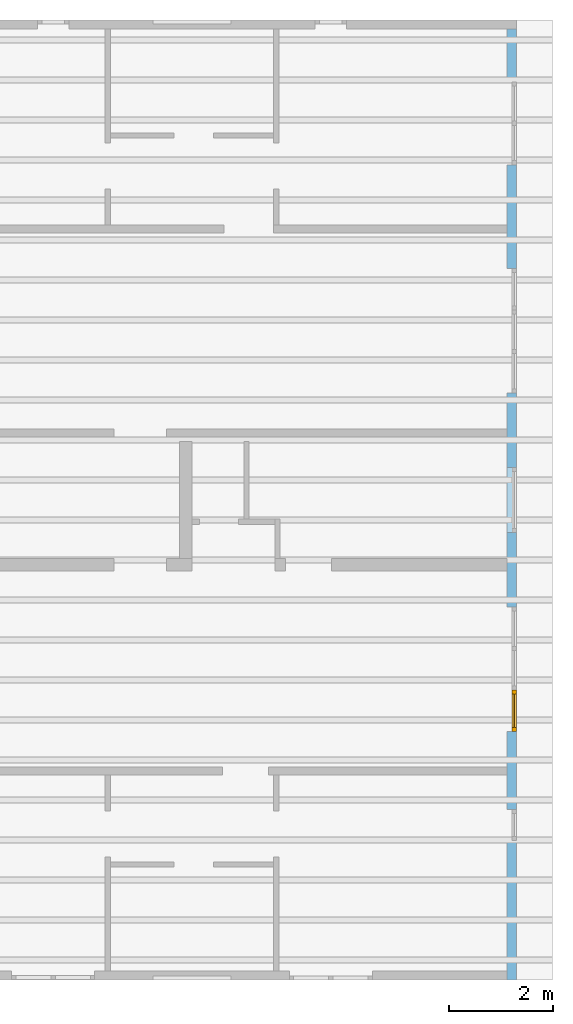
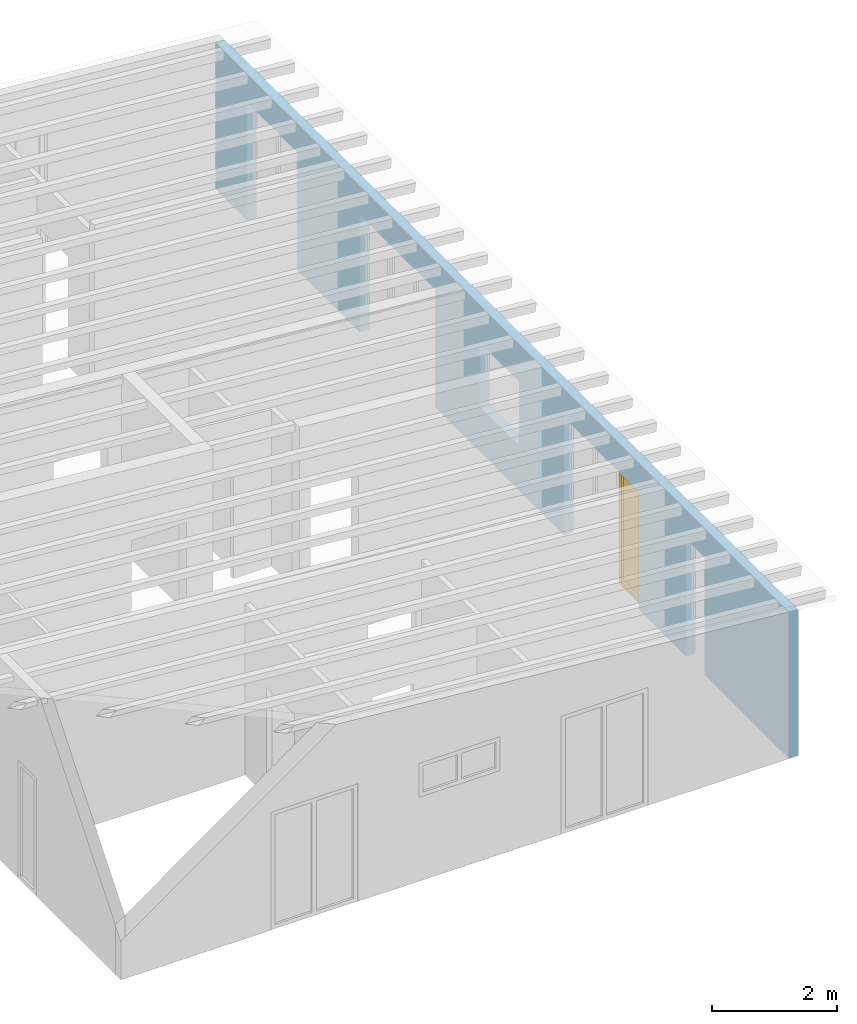
# One storey, part 11 of 13: 1 window, 7 openings, plus 1 element that does not belong to this part.
"""IFC2X3 building model written with IfcOpenShell, lengths in millimetres."""

from ifc_helpers import new_model, entity, si_unit, converted_unit, frame, frame_2d, origin, origin_with_axes, place, context, project, spatial, rectangle, extrude, clip, halfspace, faceted_brep, material, layer, layer_set, layer_usage, element, fill, save


model = new_model("IFC2X3")

# Units and contexts
model_context = context("Model", 3, precision=1e-05, world=origin())
plan_context = context("Plan", 3, precision=1e-05, world=origin())
ifc_project = project(units=[si_unit("LENGTHUNIT", "METRE", prefix="MILLI"), converted_unit("PLANEANGLEUNIT", "DEGREE", entity("IfcPlaneAngleMeasure", 0.0174532925199433), si_unit("PLANEANGLEUNIT", "RADIAN"), dimensions=[0, 0, 0, 0, 0, 0, 0]), si_unit("AREAUNIT", "SQUARE_METRE"), si_unit("VOLUMEUNIT", "CUBIC_METRE")], contexts=[model_context, plan_context])

# Building, storey
building_placement = place(None, origin())
building = spatial("IfcBuilding", under=ifc_project, at=building_placement, CompositionType="ELEMENT")
storey_placement = place(building_placement, frame((0.0, 0.0, 4770.0), z_axis=(0.0, 0.0, 1.0), x_axis=(1.0, 0.0, 0.0)))
storey = spatial("IfcBuildingStorey", under=building, at=storey_placement, Name="Geschoss", CompositionType="ELEMENT", Elevation=4770.0)

# Wall, openings, window
ifc_material_1 = material()
ifc_layer = layer(ifc_material_1, 175.000000044703)
ifc_layer_set = layer_set([ifc_layer])
ifc_layer_usage = layer_usage(ifc_layer_set, "AXIS2", "POSITIVE", 0.0)
wall_placement = place(storey_placement, frame((33688.3517822139, -8691.5625, 0.0), z_axis=(0.0, 0.0, 1.0), x_axis=(0.0, 1.0, 0.0)))
wall = element("IfcWallStandardCase", 1, at=wall_placement, inside=storey, material=ifc_layer_usage, context=model_context, shape_type="Clipping", body=[
    clip(extrude(rectangle(XDim=18325.0, YDim=175.000000044703, at=frame_2d((9162.5, 87.5000000223517), x_axis=(1.0, 0.0))), origin_with_axes(), (0.0, 0.0, 1.0), 2862.31051612095), halfspace(frame((18325.0, 175.000000044703, 2862.31051612095), z_axis=(0.0, 0.0871557427476584, -0.996194698091746), x_axis=(1.0, 0.0, 0.0)), True)),
])
opening_1_placement = place(wall_placement, frame((8625.0, 1.86264514923096e-09, 875.0), z_axis=(0.0, 1.0, 0.0), x_axis=(0.0, 0.0, 1.0)))
element("IfcOpeningElement", 2, at=opening_1_placement, cuts=wall, ObjectType="Opening", context=model_context, shape_type="SweptSolid", body=[
    extrude(rectangle(XDim=1250.0, YDim=1250.0, at=frame_2d((625.0, 625.0), x_axis=(1.0, 0.0))), origin_with_axes(), (0.0, 0.0, 1.0), 175.000000044703),
])
opening_2_placement = place(wall_placement, frame((5590.0, 0.0, 0.0), z_axis=(0.0, 1.0, 0.0), x_axis=(0.0, 0.0, 1.0)))
element("IfcOpeningElement", 3, at=opening_2_placement, cuts=wall, ObjectType="Opening", context=model_context, shape_type="SweptSolid", body=[
    extrude(rectangle(XDim=2300.0, YDim=1600.0, at=frame_2d((1150.0, 800.0), x_axis=(1.0, 0.0))), origin_with_axes(), (0.0, 0.0, 1.0), 175.000000044703),
])
opening_3_placement = place(wall_placement, frame((2690.0, 0.0, 0.0), z_axis=(0.0, 1.0, 0.0), x_axis=(0.0, 0.0, 1.0)))
element("IfcOpeningElement", 4, at=opening_3_placement, cuts=wall, ObjectType="Opening", context=model_context, shape_type="SweptSolid", body=[
    extrude(rectangle(XDim=2300.0, YDim=600.0, at=frame_2d((1150.0, 300.0), x_axis=(1.0, 0.0))), origin_with_axes(), (0.0, 0.0, 1.0), 175.000000044703),
])
opening_4_placement = place(wall_placement, frame((11310.0, 0.0, 0.0), z_axis=(0.0, 1.0, 0.0), x_axis=(0.0, 0.0, 1.0)))
element("IfcOpeningElement", 5, at=opening_4_placement, cuts=wall, ObjectType="Opening", context=model_context, shape_type="SweptSolid", body=[
    extrude(rectangle(XDim=2300.0, YDim=1600.0, at=frame_2d((1150.0, 800.0), x_axis=(1.0, 0.0))), origin_with_axes(), (0.0, 0.0, 1.0), 175.000000044703),
])
opening_5_placement = place(wall_placement, frame((15710.0, 0.0, 0.0), z_axis=(0.0, 1.0, 0.0), x_axis=(0.0, 0.0, 1.0)))
element("IfcOpeningElement", 6, at=opening_5_placement, cuts=wall, ObjectType="Opening", context=model_context, shape_type="SweptSolid", body=[
    extrude(rectangle(XDim=2300.0, YDim=1600.0, at=frame_2d((1150.0, 800.0), x_axis=(1.0, 0.0))), origin_with_axes(), (0.0, 0.0, 1.0), 175.000000044703),
])
opening_6_placement = place(wall_placement, frame((12910.0, 0.0, 0.0), z_axis=(0.0, 1.0, 0.0), x_axis=(0.0, 0.0, 1.0)))
element("IfcOpeningElement", 7, at=opening_6_placement, cuts=wall, ObjectType="Opening", context=model_context, shape_type="SweptSolid", body=[
    extrude(rectangle(XDim=2300.0, YDim=800.0, at=frame_2d((1150.0, 400.0), x_axis=(1.0, 0.0))), origin_with_axes(), (0.0, 0.0, 1.0), 175.000000044703),
])
opening_7_placement = place(wall_placement, frame((4790.0, 0.0, 0.0), z_axis=(0.0, 1.0, 0.0), x_axis=(0.0, 0.0, 1.0)))
opening_7 = element("IfcOpeningElement", 8, at=opening_7_placement, cuts=wall, ObjectType="Opening", context=model_context, shape_type="SweptSolid", body=[
    extrude(rectangle(XDim=2300.0, YDim=800.0, at=frame_2d((1150.0, 400.0), x_axis=(1.0, 0.0))), origin_with_axes(), (0.0, 0.0, 1.0), 175.000000044703),
])
ifc_material_2 = material()
window_placement = place(opening_7_placement, frame((0.0, 0.0, 0.0), z_axis=(1.0, 0.0, 0.0), x_axis=(0.0, 1.0, 0.0)))
window = element("IfcWindow", 9, at=window_placement, inside=storey, material=ifc_material_2, Name="m", OverallHeight=2300.0, OverallWidth=800.0, context=model_context, shape_type="Brep", body=[
    faceted_brep([(80.0, 4.19088097558529e-11, 0.0), (0.0, 4.19235757220804e-11, 0.0), (0.0, 4.19235757220804e-11, 2300.0), (80.0, 4.19088097558529e-11, 2300.0), (0.0, 80.0000000000419, 0.0), (80.0, 80.0000000000419, 0.0), (80.0, 80.0000000000419, 2300.0), (0.0, 80.0000000000419, 2300.0), (0.0, 4.19235757220804e-11, 0.0), (80.0, 4.19088097558529e-11, 0.0), (80.0, 80.0000000000419, 0.0), (0.0, 80.0000000000419, 0.0), (0.0, 4.19235757220804e-11, 2300.0), (0.0, 4.19235757220804e-11, 0.0), (0.0, 80.0000000000419, 0.0), (0.0, 80.0000000000419, 2300.0), (80.0, 4.19088097558529e-11, 2300.0), (0.0, 4.19235757220804e-11, 2300.0), (0.0, 80.0000000000419, 2300.0), (80.0, 80.0000000000419, 2300.0), (80.0, 4.19088097558529e-11, 0.0), (80.0, 4.19088097558529e-11, 2300.0), (80.0, 80.0000000000419, 2300.0), (80.0, 80.0000000000419, 0.0)], [[[0, 1, 2, 3]], [[4, 5, 6, 7]], [[8, 9, 10, 11]], [[12, 13, 14, 15]], [[16, 17, 18, 19]], [[20, 21, 22, 23]]], orient=[[False], [False], [False], [False], [False], [False]]),
    faceted_brep([(720.0, 4.17628154281147e-11, 2300.0), (800.0, 4.17481604841896e-11, 2300.0), (800.0, 4.17481604841896e-11, 0.0), (720.0, 4.17628154281147e-11, 0.0), (800.0, 80.0000000000418, 2300.0), (720.0, 80.0000000000418, 2300.0), (720.0, 80.0000000000418, 0.0), (800.0, 80.0000000000418, 0.0), (800.0, 4.17481604841896e-11, 2300.0), (720.0, 4.17628154281147e-11, 2300.0), (720.0, 80.0000000000418, 2300.0), (800.0, 80.0000000000418, 2300.0), (800.0, 4.17481604841896e-11, 0.0), (800.0, 4.17481604841896e-11, 2300.0), (800.0, 80.0000000000418, 2300.0), (800.0, 80.0000000000418, 0.0), (720.0, 4.17628154281147e-11, 0.0), (800.0, 4.17481604841896e-11, 0.0), (800.0, 80.0000000000418, 0.0), (720.0, 80.0000000000418, 0.0), (720.0, 4.17628154281147e-11, 2300.0), (720.0, 4.17628154281147e-11, 0.0), (720.0, 80.0000000000418, 0.0), (720.0, 80.0000000000418, 2300.0)], [[[0, 1, 2, 3]], [[4, 5, 6, 7]], [[8, 9, 10, 11]], [[12, 13, 14, 15]], [[16, 17, 18, 19]], [[20, 21, 22, 23]]], orient=[[False], [False], [False], [False], [False], [False]]),
    faceted_brep([(720.0, 4.17486045733995e-11, 80.0), (720.0, 4.17486045733995e-11, 0.0), (80.0, 4.18661771917073e-11, 0.0), (80.0, 4.18661771917073e-11, 80.0), (720.0, 80.0000000000418, 0.0), (720.0, 80.0000000000418, 80.0), (80.0, 80.0000000000419, 80.0), (80.0, 80.0000000000419, 0.0), (720.0, 4.17486045733995e-11, 0.0), (720.0, 4.17486045733995e-11, 80.0), (720.0, 80.0000000000418, 80.0), (720.0, 80.0000000000418, 0.0), (80.0, 4.18661771917073e-11, 0.0), (720.0, 4.17486045733995e-11, 0.0), (720.0, 80.0000000000418, 0.0), (80.0, 80.0000000000419, 0.0), (80.0, 4.18661771917073e-11, 80.0), (80.0, 4.18661771917073e-11, 0.0), (80.0, 80.0000000000419, 0.0), (80.0, 80.0000000000419, 80.0), (720.0, 4.17486045733995e-11, 80.0), (80.0, 4.18661771917073e-11, 80.0), (80.0, 80.0000000000419, 80.0), (720.0, 80.0000000000418, 80.0)], [[[0, 1, 2, 3]], [[4, 5, 6, 7]], [[8, 9, 10, 11]], [[12, 13, 14, 15]], [[16, 17, 18, 19]], [[20, 21, 22, 23]]], orient=[[False], [False], [False], [False], [False], [False]]),
    faceted_brep([(80.0, 4.18661771917073e-11, 2220.0), (80.0, 4.18661771917073e-11, 2300.0), (720.0, 4.17486045733995e-11, 2300.0), (720.0, 4.17486045733995e-11, 2220.0), (80.0, 80.0000000000419, 2300.0), (80.0, 80.0000000000419, 2220.0), (720.0, 80.0000000000418, 2220.0), (720.0, 80.0000000000418, 2300.0), (80.0, 4.18661771917073e-11, 2300.0), (80.0, 4.18661771917073e-11, 2220.0), (80.0, 80.0000000000419, 2220.0), (80.0, 80.0000000000419, 2300.0), (720.0, 4.17486045733995e-11, 2300.0), (80.0, 4.18661771917073e-11, 2300.0), (80.0, 80.0000000000419, 2300.0), (720.0, 80.0000000000418, 2300.0), (720.0, 4.17486045733995e-11, 2220.0), (720.0, 4.17486045733995e-11, 2300.0), (720.0, 80.0000000000418, 2300.0), (720.0, 80.0000000000418, 2220.0), (80.0, 4.18661771917073e-11, 2220.0), (720.0, 4.17486045733995e-11, 2220.0), (720.0, 80.0000000000418, 2220.0), (80.0, 80.0000000000419, 2220.0)], [[[0, 1, 2, 3]], [[4, 5, 6, 7]], [[8, 9, 10, 11]], [[12, 13, 14, 15]], [[16, 17, 18, 19]], [[20, 21, 22, 23]]], orient=[[False], [False], [False], [False], [False], [False]]),
    faceted_brep([(720.0, 40.0000000000418, 2220.0), (720.0, 40.0000000000418, 80.0), (80.0, 40.0000000000419, 80.0), (80.0, 40.0000000000419, 2220.0), (720.0, 41.0000000000418, 2220.0), (80.0, 41.0000000000419, 2220.0), (80.0, 41.0000000000419, 80.0), (720.0, 41.0000000000418, 80.0), (720.0, 40.0000000000418, 2220.0), (720.0, 41.0000000000418, 2220.0), (720.0, 41.0000000000418, 80.0), (720.0, 40.0000000000418, 80.0), (720.0, 40.0000000000418, 80.0), (720.0, 41.0000000000418, 80.0), (80.0, 41.0000000000419, 80.0), (80.0, 40.0000000000419, 80.0), (80.0, 40.0000000000419, 80.0), (80.0, 41.0000000000419, 80.0), (80.0, 41.0000000000419, 2220.0), (80.0, 40.0000000000419, 2220.0), (80.0, 40.0000000000419, 2220.0), (80.0, 41.0000000000419, 2220.0), (720.0, 41.0000000000418, 2220.0), (720.0, 40.0000000000418, 2220.0)], [[[0, 1, 2, 3]], [[4, 5, 6, 7]], [[8, 9, 10, 11]], [[12, 13, 14, 15]], [[16, 17, 18, 19]], [[20, 21, 22, 23]]], orient=[[False], [False], [False], [False], [False], [False]]),
])
fill(opening_7, window)

save(model, "model.ifc")
